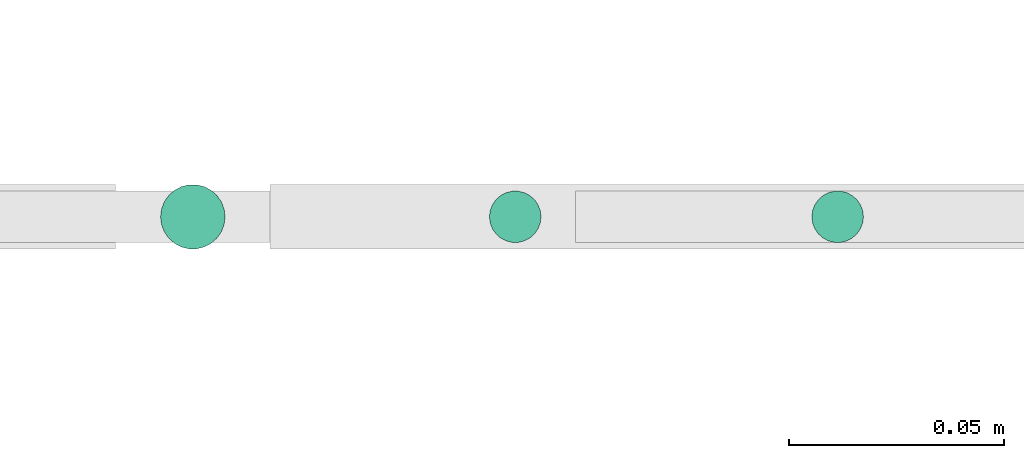
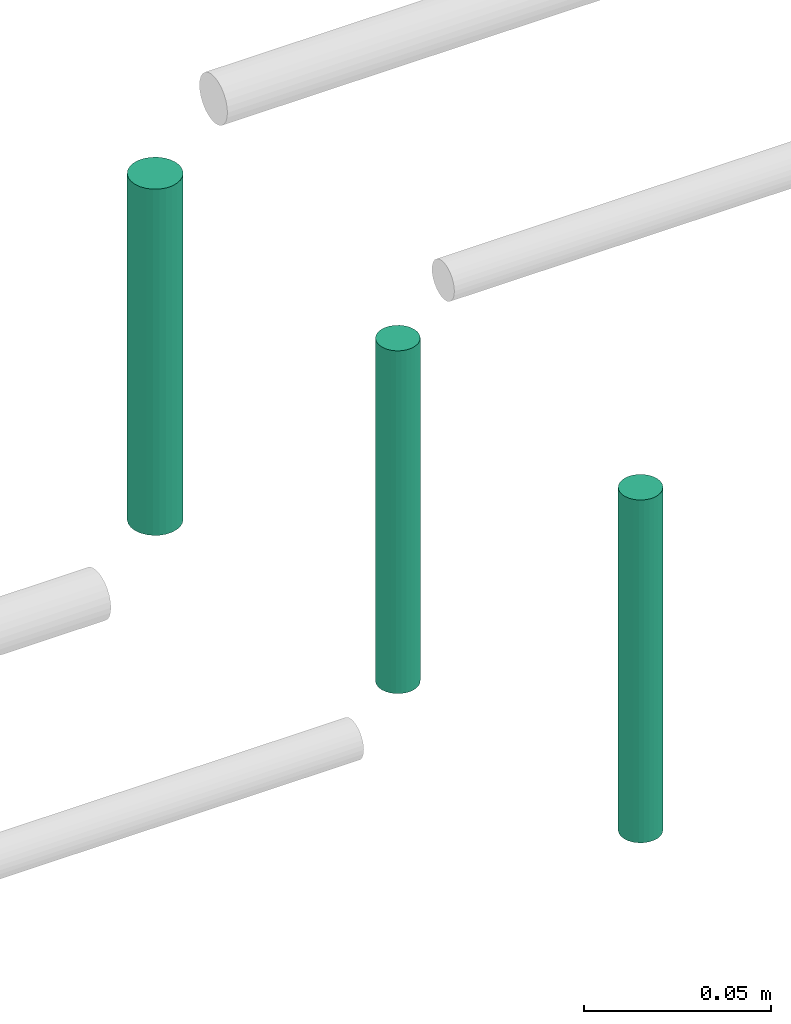
# One storey, part 38 of 89: 3 flow segments.
"""IFC2X3 building model written with IfcOpenShell, lengths in millimetres."""

from ifc_helpers import new_model, entity, si_unit, converted_unit, derived_unit, direction, frame, frame_2d, origin, origin_2d_with_axis, place, context, subcontext, project, spatial, circle, extrude, type_object, element, save


model = new_model("IFC2X3")

# Units and contexts
model_context = context("Model", 3, precision=0.01, world=origin(), true_north=direction((6.12303176911189e-17, 1.0)))
body_context = subcontext(model_context, "Body", "Model", "MODEL_VIEW")
ifc_project = project(units=[si_unit("LENGTHUNIT", "METRE", prefix="MILLI"), si_unit("AREAUNIT", "SQUARE_METRE"), si_unit("VOLUMEUNIT", "CUBIC_METRE"), converted_unit("PLANEANGLEUNIT", "DEGREE", entity("IfcRatioMeasure", 0.0174532925199433), si_unit("PLANEANGLEUNIT", "RADIAN"), dimensions=[0, 0, 0, 0, 0, 0, 0]), si_unit("MASSUNIT", "GRAM", prefix="KILO"), derived_unit("MASSDENSITYUNIT", [(si_unit("MASSUNIT", "GRAM", prefix="KILO"), 1), (si_unit("LENGTHUNIT", "METRE"), -3)]), derived_unit("MOMENTOFINERTIAUNIT", [(si_unit("LENGTHUNIT", "METRE"), 4)]), si_unit("TIMEUNIT", "SECOND"), si_unit("FREQUENCYUNIT", "HERTZ"), si_unit("THERMODYNAMICTEMPERATUREUNIT", "DEGREE_CELSIUS"), derived_unit("THERMALTRANSMITTANCEUNIT", [(si_unit("MASSUNIT", "GRAM", prefix="KILO"), 1), (si_unit("THERMODYNAMICTEMPERATUREUNIT", "KELVIN"), -1), (si_unit("TIMEUNIT", "SECOND"), -3)]), derived_unit("VOLUMETRICFLOWRATEUNIT", [(si_unit("LENGTHUNIT", "METRE"), 3), (si_unit("TIMEUNIT", "SECOND"), -1)]), derived_unit("MASSFLOWRATEUNIT", [(si_unit("MASSUNIT", "GRAM", prefix="KILO"), 1), (si_unit("TIMEUNIT", "SECOND"), -1)]), derived_unit("ROTATIONALFREQUENCYUNIT", [(si_unit("TIMEUNIT", "SECOND"), -1)]), si_unit("ELECTRICCURRENTUNIT", "AMPERE"), si_unit("ELECTRICVOLTAGEUNIT", "VOLT"), si_unit("POWERUNIT", "WATT"), si_unit("FORCEUNIT", "NEWTON", prefix="KILO"), si_unit("ILLUMINANCEUNIT", "LUX"), si_unit("LUMINOUSFLUXUNIT", "LUMEN"), si_unit("LUMINOUSINTENSITYUNIT", "CANDELA"), derived_unit("USERDEFINED", [(si_unit("MASSUNIT", "GRAM", prefix="KILO"), -1), (si_unit("LENGTHUNIT", "METRE"), -2), (si_unit("TIMEUNIT", "SECOND"), 3), (si_unit("LUMINOUSFLUXUNIT", "LUMEN"), 1)]), derived_unit("LINEARVELOCITYUNIT", [(si_unit("LENGTHUNIT", "METRE"), 1), (si_unit("TIMEUNIT", "SECOND"), -1)]), si_unit("PRESSUREUNIT", "PASCAL"), derived_unit("USERDEFINED", [(si_unit("LENGTHUNIT", "METRE"), -2), (si_unit("MASSUNIT", "GRAM", prefix="KILO"), 1), (si_unit("TIMEUNIT", "SECOND"), -2)]), derived_unit("LINEARFORCEUNIT", [(si_unit("MASSUNIT", "GRAM", prefix="KILO"), 1), (si_unit("LENGTHUNIT", "METRE"), 1), (si_unit("TIMEUNIT", "SECOND"), -2), (si_unit("LENGTHUNIT", "METRE"), -1)]), derived_unit("PLANARFORCEUNIT", [(si_unit("MASSUNIT", "GRAM", prefix="KILO"), 1), (si_unit("LENGTHUNIT", "METRE"), 1), (si_unit("TIMEUNIT", "SECOND"), -2), (si_unit("LENGTHUNIT", "METRE"), -2)])], contexts=[model_context])

# Site, building, storey
site_placement = place(None, frame((0.0, -0.00077364408347762, 0.0)))
site = spatial("IfcSite", under=ifc_project, at=site_placement, CompositionType="ELEMENT")
building_placement = place(site_placement, origin())
building = spatial("IfcBuilding", under=site, at=building_placement, CompositionType="ELEMENT")
storey_placement = place(building_placement, frame((0.0, 0.0, 24000.0)))
storey = spatial("IfcBuildingStorey", under=building, at=storey_placement, CompositionType="ELEMENT", Elevation=24000.0)

# Flow segments
pipe_segment_type = type_object("IfcPipeSegmentType", PredefinedType="NOTDEFINED")
flow_segment_1_placement = place(storey_placement, frame((24826.7436346567, 9267.40472776408, -5536.0)))
element("IfcFlowSegment", 1, at=flow_segment_1_placement, inside=storey, type_object=pipe_segment_type, context=body_context, shape_type="SweptSolid", body=[
    extrude(circle(Radius=6.0, at=frame_2d((0.0, -1.08286712929839e-12), x_axis=(1.0, 0.0))), frame((7.59527223591454, 7.59527223591454, 0.0), z_axis=(0.0, 0.0, 1.0), x_axis=(-1.0, 0.0, 0.0)), (0.0, 0.0, 1.0), 111.999999999983),
])
flow_segment_2_placement = place(storey_placement, frame((24751.7436346567, 9267.40472776417, -5461.0)))
element("IfcFlowSegment", 2, at=flow_segment_2_placement, inside=storey, type_object=pipe_segment_type, context=body_context, shape_type="SweptSolid", body=[
    extrude(circle(Radius=6.0, at=origin_2d_with_axis()), frame((7.59527223591454, 7.59527223591562, 0.0)), (0.0, 0.0, 1.0), 112.000000000014),
])
flow_segment_3_placement = place(storey_placement, frame((24675.2436346567, 9265.90472776446, -5382.0)))
element("IfcFlowSegment", 3, at=flow_segment_3_placement, inside=storey, type_object=pipe_segment_type, context=body_context, shape_type="SweptSolid", body=[
    extrude(circle(Radius=7.5, at=origin_2d_with_axis()), frame((9.09527223591419, 9.09527223591636, 0.0)), (0.0, 0.0, 1.0), 113.123247988002),
])

save(model, "model.ifc")
